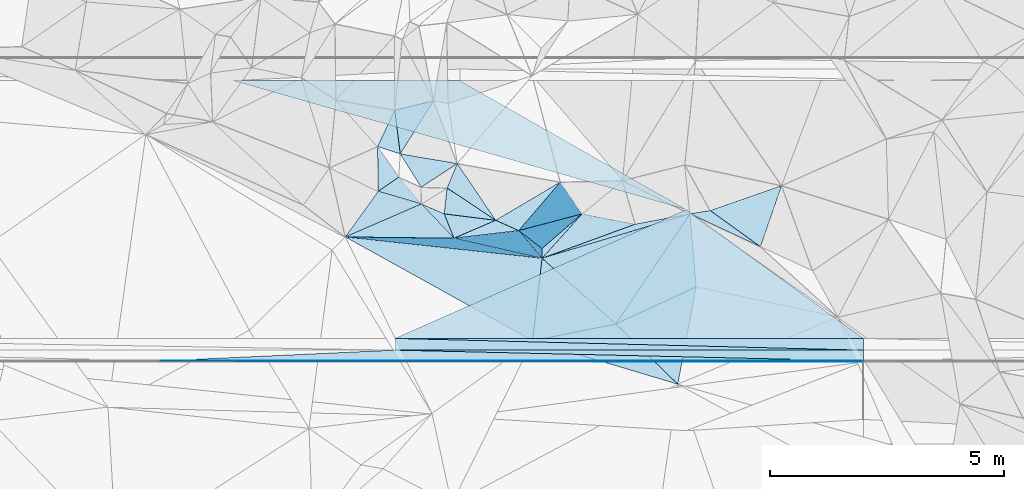
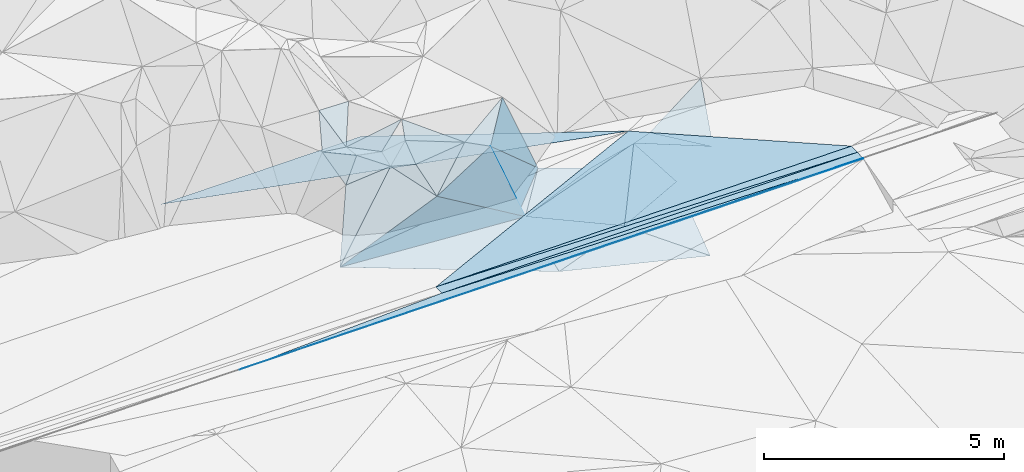
# One storey, part 48 of 275: 49 plates.
"""IFC2X3 building model written with IfcOpenShell, lengths in millimetres."""

from ifc_helpers import new_model, si_unit, frame, origin_with_axes, place, context, subcontext, project, spatial, polyline, outline, extrude, material, type_object, element, save


model = new_model("IFC2X3")

# Units and contexts
model_context = context("Model", 3, precision=1e-05, world=origin_with_axes())
body_context = subcontext(model_context, "Body", "Model", "MODEL_VIEW")
ifc_project = project(units=[si_unit("LENGTHUNIT", "METRE", prefix="MILLI"), si_unit("AREAUNIT", "SQUARE_METRE"), si_unit("VOLUMEUNIT", "CUBIC_METRE"), si_unit("MASSUNIT", "GRAM", prefix="KILO"), si_unit("TIMEUNIT", "SECOND"), si_unit("PLANEANGLEUNIT", "RADIAN"), si_unit("SOLIDANGLEUNIT", "STERADIAN"), si_unit("THERMODYNAMICTEMPERATUREUNIT", "DEGREE_CELSIUS"), si_unit("LUMINOUSINTENSITYUNIT", "LUMEN")], contexts=[model_context])

# Site, building, storey
site_placement = place(None, origin_with_axes())
site = spatial("IfcSite", under=ifc_project, at=site_placement, CompositionType="ELEMENT")
building_placement = place(site_placement, origin_with_axes())
building = spatial("IfcBuilding", under=site, at=building_placement, Name="Undefined", CompositionType="ELEMENT")
storey_placement = place(building_placement, origin_with_axes())
storey = spatial("IfcBuildingStorey", under=building, at=storey_placement, Name="Undefined", CompositionType="ELEMENT", Elevation=0.0)

# Plates
ifc_material = material()
plate_type_1 = type_object("IfcPlateType", PredefinedType="NOTDEFINED")
for number, where, z_axis, x_axis, name in (
    (1, (-124610.502362477, 63294.0443863483, 49008.9291654633), (0.008324340579686, 0.024990848492353, -0.999653021225638), (0.808589546700831, -0.588319091752625, -0.00797441192262458), "00_PR"),
    (2, (-124610.502362477, 63294.0443863483, 49008.9291654633), (0.008324340579686, 0.024990848492353, -0.999653021225638), (0.808589546700831, -0.588319091752625, -0.00797441192262458), "00_PR"),
    (3, (-124610.502362477, 63294.0443863483, 49008.9291654633), (0.008324340579686, 0.024990848492353, -0.999653021225638), (0.808589546700831, -0.588319091752625, -0.00797441192262458), "00_PR"),
):
    element("IfcPlate", number, at=place(storey_placement, frame(where, z_axis=z_axis, x_axis=x_axis)), inside=storey, type_object=plate_type_1, material=ifc_material, Name=name, context=body_context, shape_type="SweptSolid", body=[
        extrude(outline(polyline([(0.0, 0.0), (4674.70166015625, 3.60887497663498e-09), (-3410.86694335938, 5884.76953125), (0.0, 0.0)])), frame((-8.85201319254618e-08, 2.18876761149539e-07, -0.5000001331573), z_axis=(0.0, 0.0, 1.0), x_axis=(1.0, 0.0, 0.0)), (0.0, 0.0, 1.0), 1.0),
    ])
plate_type_2 = type_object("IfcPlateType", PredefinedType="NOTDEFINED")
plate_1_placement = place(storey_placement, frame((-120830.601639584, 60293.8280401885, 48965.3971659145), z_axis=(0.008324340579686, 0.024990848492353, -0.999653021225638), x_axis=(-0.999965344853481, 5.72919765649429e-05, -0.00832501109232228)))
element("IfcPlate", 4, at=plate_1_placement, inside=storey, type_object=plate_type_2, material=ifc_material, Name="00_PR", context=body_context, shape_type="SweptSolid", body=[
    extrude(outline(polyline([(0.0, 0.0), (10000.3466796875, 4.4623448047787e-08), (10000.294921875, 250.078109741211), (0.0, 0.0)])), frame((-8.85201319254618e-08, 2.18876761149539e-07, -0.5000001331573), z_axis=(0.0, 0.0, 1.0), x_axis=(1.0, 0.0, 0.0)), (0.0, 0.0, 1.0), 1.0),
])
plate_2_placement = place(storey_placement, frame((-120830.587315527, 60543.8280489618, 48971.6511662542), z_axis=(0.00832424080938101, 0.0250068329668296, -0.999652622324334), x_axis=(-5.72749691740062e-05, -0.999687245018328, -0.0250081760079334)))
element("IfcPlate", 5, at=plate_2_placement, inside=storey, type_object=plate_type_2, material=ifc_material, Name="00_PR", context=body_context, shape_type="SweptSolid", body=[
    extrude(outline(polyline([(0.0, 0.0), (250.078216552734, 4.07453626394272e-10), (2.08209180831909, 10000.3466796875), (0.0, 0.0)])), frame((-8.85201319254618e-08, 2.18876761149539e-07, -0.5000001331573), z_axis=(0.0, 0.0, 1.0), x_axis=(1.0, 0.0, 0.0)), (0.0, 0.0, 1.0), 1.0),
])
plate_3_placement = place(storey_placement, frame((-120830.601639584, 60293.8280401885, 48965.3971659145), z_axis=(0.008324340579686, 0.024990848492353, -0.999653021225638), x_axis=(-0.999965344853481, 5.72919765649429e-05, -0.00832501109232228)))
element("IfcPlate", 6, at=plate_3_placement, inside=storey, type_object=plate_type_2, material=ifc_material, Name="00_PR", context=body_context, shape_type="SweptSolid", body=[
    extrude(outline(polyline([(0.0, 0.0), (10000.3466796875, 4.4623448047787e-08), (10000.294921875, 250.078109741211), (0.0, 0.0)])), frame((-8.85201319254618e-08, 2.18876761149539e-07, -0.5000001331573), z_axis=(0.0, 0.0, 1.0), x_axis=(1.0, 0.0, 0.0)), (0.0, 0.0, 1.0), 1.0),
])
plate_4_placement = place(storey_placement, frame((-120830.587315527, 60543.8280489618, 48971.6511662542), z_axis=(0.00832424080938101, 0.0250068329668296, -0.999652622324334), x_axis=(-5.72749691740062e-05, -0.999687245018328, -0.0250081760079334)))
element("IfcPlate", 7, at=plate_4_placement, inside=storey, type_object=plate_type_2, material=ifc_material, Name="00_PR", context=body_context, shape_type="SweptSolid", body=[
    extrude(outline(polyline([(0.0, 0.0), (250.078216552734, 4.07453626394272e-10), (2.08209180831909, 10000.3466796875), (0.0, 0.0)])), frame((-8.85201319254618e-08, 2.18876761149539e-07, -0.5000001331573), z_axis=(0.0, 0.0, 1.0), x_axis=(1.0, 0.0, 0.0)), (0.0, 0.0, 1.0), 1.0),
])
plate_5_placement = place(storey_placement, frame((-120830.601639584, 60293.8280401885, 48965.3971659145), z_axis=(0.008324340579686, 0.024990848492353, -0.999653021225638), x_axis=(-0.999965344853481, 5.72919765649429e-05, -0.00832501109232228)))
element("IfcPlate", 8, at=plate_5_placement, inside=storey, type_object=plate_type_2, material=ifc_material, Name="00_PR", context=body_context, shape_type="SweptSolid", body=[
    extrude(outline(polyline([(0.0, 0.0), (10000.3466796875, 4.4623448047787e-08), (10000.294921875, 250.078109741211), (0.0, 0.0)])), frame((-8.85201319254618e-08, 2.18876761149539e-07, -0.5000001331573), z_axis=(0.0, 0.0, 1.0), x_axis=(1.0, 0.0, 0.0)), (0.0, 0.0, 1.0), 1.0),
])
plate_6_placement = place(storey_placement, frame((-120830.587315527, 60543.8280489618, 48971.6511662542), z_axis=(0.00832424080938101, 0.0250068329668296, -0.999652622324334), x_axis=(-5.72749691740062e-05, -0.999687245018328, -0.0250081760079334)))
element("IfcPlate", 9, at=plate_6_placement, inside=storey, type_object=plate_type_2, material=ifc_material, Name="00_PR", context=body_context, shape_type="SweptSolid", body=[
    extrude(outline(polyline([(0.0, 0.0), (250.078216552734, 4.07453626394272e-10), (2.08209180831909, 10000.3466796875), (0.0, 0.0)])), frame((-8.85201319254618e-08, 2.18876761149539e-07, -0.5000001331573), z_axis=(0.0, 0.0, 1.0), x_axis=(1.0, 0.0, 0.0)), (0.0, 0.0, 1.0), 1.0),
])
plate_type_3 = type_object("IfcPlateType", PredefinedType="NOTDEFINED")
for number, where, z_axis, x_axis, name in (
    (10, (-135830.614983984, 60064.7000444183, 48829.0156227603), (0.00831779862514196, 0.049539601639022, -0.998737524125072), (0.999965340787191, -5.73519775278889e-05, 0.0083254990906575), "00_PR"),
    (11, (-135830.614983984, 60064.7000444183, 48829.0156227603), (0.00831779862514196, 0.049539601639022, -0.998737524125072), (0.999965340787191, -5.73519775278889e-05, 0.0083254990906575), "00_PR"),
    (12, (-135830.614983984, 60064.7000444183, 48829.0156227603), (0.00831779862514196, 0.049539601639022, -0.998737524125072), (0.999965340787191, -5.73519775278889e-05, 0.0083254990906575), "00_PR"),
):
    element("IfcPlate", number, at=place(storey_placement, frame(where, z_axis=z_axis, x_axis=x_axis)), inside=storey, type_object=plate_type_3, material=ifc_material, Name=name, context=body_context, shape_type="SweptSolid", body=[
        extrude(outline(polyline([(0.0, 0.0), (15000.51953125, -1.61511707119644e-07), (15000.51171875, 20.0235919952393), (0.0, 0.0)])), frame((-8.85201319254618e-08, 2.18876761149539e-07, -0.5000001331573), z_axis=(0.0, 0.0, 1.0), x_axis=(1.0, 0.0, 0.0)), (0.0, 0.0, 1.0), 1.0),
    ])
plate_type_4 = type_object("IfcPlateType", PredefinedType="NOTDEFINED")
plate_7_placement = place(storey_placement, frame((-130830.60171673, 60294.413452539, 48882.1446321262), z_axis=(0.00831765539205462, 0.0499426003588408, -0.998717454177194), x_axis=(0.999708562495105, -0.0230507050000655, 0.00717321914976939)))
element("IfcPlate", 13, at=plate_7_placement, inside=storey, type_object=plate_type_4, material=ifc_material, Name="00_PR", context=body_context, shape_type="SweptSolid", body=[
    extrude(outline(polyline([(0.0, 0.0), (10002.9013671875, 4.3117324821651e-08), (-4993.64208984375, 345.343017578125), (0.0, 0.0)])), frame((-8.85201319254618e-08, 2.18876761149539e-07, -0.5000001331573), z_axis=(0.0, 0.0, 1.0), x_axis=(1.0, 0.0, 0.0)), (0.0, 0.0, 1.0), 1.0),
])
plate_8_placement = place(storey_placement, frame((-120830.601646001, 60293.8405085212, 48965.3976334797), z_axis=(0.00831748675117263, 0.049935177931012, -0.998717826725418), x_axis=(-5.96829523358933e-05, -0.998752347891058, -0.0499374010141037)))
element("IfcPlate", 14, at=plate_8_placement, inside=storey, type_object=plate_type_4, material=ifc_material, Name="00_PR", context=body_context, shape_type="SweptSolid", body=[
    extrude(outline(polyline([(0.0, 0.0), (230.288314819336, -3.49245965480804e-10), (4.18204641342163, 10000.345703125), (0.0, 0.0)])), frame((-8.85201319254618e-08, 2.18876761149539e-07, -0.5000001331573), z_axis=(0.0, 0.0, 1.0), x_axis=(1.0, 0.0, 0.0)), (0.0, 0.0, 1.0), 1.0),
])
plate_9_placement = place(storey_placement, frame((-130830.60171673, 60294.413452539, 48882.1446321262), z_axis=(0.00831765539205462, 0.0499426003588408, -0.998717454177194), x_axis=(0.999708562495105, -0.0230507050000655, 0.00717321914976939)))
element("IfcPlate", 15, at=plate_9_placement, inside=storey, type_object=plate_type_4, material=ifc_material, Name="00_PR", context=body_context, shape_type="SweptSolid", body=[
    extrude(outline(polyline([(0.0, 0.0), (10002.9013671875, 4.3117324821651e-08), (-4993.64208984375, 345.343017578125), (0.0, 0.0)])), frame((-8.85201319254618e-08, 2.18876761149539e-07, -0.5000001331573), z_axis=(0.0, 0.0, 1.0), x_axis=(1.0, 0.0, 0.0)), (0.0, 0.0, 1.0), 1.0),
])
plate_10_placement = place(storey_placement, frame((-120830.601646001, 60293.8405085212, 48965.3976334797), z_axis=(0.00831748675117263, 0.049935177931012, -0.998717826725418), x_axis=(-5.96829523358933e-05, -0.998752347891058, -0.0499374010141037)))
element("IfcPlate", 16, at=plate_10_placement, inside=storey, type_object=plate_type_4, material=ifc_material, Name="00_PR", context=body_context, shape_type="SweptSolid", body=[
    extrude(outline(polyline([(0.0, 0.0), (230.288314819336, -3.49245965480804e-10), (4.18204641342163, 10000.345703125), (0.0, 0.0)])), frame((-8.85201319254618e-08, 2.18876761149539e-07, -0.5000001331573), z_axis=(0.0, 0.0, 1.0), x_axis=(1.0, 0.0, 0.0)), (0.0, 0.0, 1.0), 1.0),
])
plate_11_placement = place(storey_placement, frame((-130830.60171673, 60294.413452539, 48882.1446321262), z_axis=(0.00831765539205462, 0.0499426003588408, -0.998717454177194), x_axis=(0.999708562495105, -0.0230507050000655, 0.00717321914976939)))
element("IfcPlate", 17, at=plate_11_placement, inside=storey, type_object=plate_type_4, material=ifc_material, Name="00_PR", context=body_context, shape_type="SweptSolid", body=[
    extrude(outline(polyline([(0.0, 0.0), (10002.9013671875, 4.3117324821651e-08), (-4993.64208984375, 345.343017578125), (0.0, 0.0)])), frame((-8.85201319254618e-08, 2.18876761149539e-07, -0.5000001331573), z_axis=(0.0, 0.0, 1.0), x_axis=(1.0, 0.0, 0.0)), (0.0, 0.0, 1.0), 1.0),
])
plate_12_placement = place(storey_placement, frame((-120830.601646001, 60293.8405085212, 48965.3976334797), z_axis=(0.00831748675117263, 0.049935177931012, -0.998717826725418), x_axis=(-5.96829523358933e-05, -0.998752347891058, -0.0499374010141037)))
element("IfcPlate", 18, at=plate_12_placement, inside=storey, type_object=plate_type_4, material=ifc_material, Name="00_PR", context=body_context, shape_type="SweptSolid", body=[
    extrude(outline(polyline([(0.0, 0.0), (230.288314819336, -3.49245965480804e-10), (4.18204641342163, 10000.345703125), (0.0, 0.0)])), frame((-8.85201319254618e-08, 2.18876761149539e-07, -0.5000001331573), z_axis=(0.0, 0.0, 1.0), x_axis=(1.0, 0.0, 0.0)), (0.0, 0.0, 1.0), 1.0),
])
plate_type_5 = type_object("IfcPlateType", PredefinedType="NOTDEFINED")
plate_13_placement = place(storey_placement, frame((-126114.695033542, 60852.7403297663, 48599.5005975447), z_axis=(0.00639754250018912, 0.0492102304275293, -0.99876795336616), x_axis=(0.557695812458765, 0.828856477377227, 0.044410817103184)))
element("IfcPlate", 19, at=plate_13_placement, inside=storey, type_object=plate_type_5, material=ifc_material, Name="00", context=body_context, shape_type="SweptSolid", body=[
    extrude(outline(polyline([(0.0, 0.0), (2837.14672851563, -1.85973476618528e-08), (1615.65490722656, 982.425109863281), (0.0, 0.0)])), frame((-8.85201319254618e-08, 2.18876761149539e-07, -0.5000001331573), z_axis=(0.0, 0.0, 1.0), x_axis=(1.0, 0.0, 0.0)), (0.0, 0.0, 1.0), 1.0),
])
plate_type_6 = type_object("IfcPlateType", PredefinedType="NOTDEFINED")
plate_14_placement = place(storey_placement, frame((-127689.030648532, 62255.3389630177, 48539.887444943), z_axis=(0.109830524960829, 0.968132294410708, -0.22507135825308), x_axis=(-0.993946047957137, 0.107641771830923, -0.0220114222050292)))
element("IfcPlate", 20, at=plate_14_placement, inside=storey, type_object=plate_type_6, material=ifc_material, Name="00", context=body_context, shape_type="SweptSolid", body=[
    extrude(outline(polyline([(0.0, 0.0), (4225.0791015625, -6.38101482763886e-09), (1894.64685058594, 987.28076171875), (0.0, 0.0)])), frame((-8.85201319254618e-08, 2.18876761149539e-07, -0.5000001331573), z_axis=(0.0, 0.0, 1.0), x_axis=(1.0, 0.0, 0.0)), (0.0, 0.0, 1.0), 1.0),
])
plate_type_7 = type_object("IfcPlateType", PredefinedType="NOTDEFINED")
plate_15_placement = place(storey_placement, frame((-130715.361903909, 64482.6576847983, 50019.5544333063), z_axis=(-0.280613128558549, 0.356665372953221, -0.891092634812298), x_axis=(-0.114092131194023, 0.909417436755586, 0.399928632789034)))
element("IfcPlate", 21, at=plate_15_placement, inside=storey, type_object=plate_type_7, material=ifc_material, Name="00", context=body_context, shape_type="SweptSolid", body=[
    extrude(outline(polyline([(0.0, 0.0), (1025.18286132813, -4.36557456851006e-10), (1042.74072265625, 871.889770507813), (0.0, 0.0)])), frame((-8.85201319254618e-08, 2.18876761149539e-07, -0.5000001331573), z_axis=(0.0, 0.0, 1.0), x_axis=(1.0, 0.0, 0.0)), (0.0, 0.0, 1.0), 1.0),
])
plate_type_8 = type_object("IfcPlateType", PredefinedType="NOTDEFINED")
for number, where, z_axis, x_axis, name in (
    (22, (-134278.700031969, 66044.5731858637, 48859.6831648337), (0.00832149793297365, -0.0249918019511436, -0.9996530210565), (0.999965340787191, -5.73519775278889e-05, 0.0083254990906575), "00_PR"),
    (23, (-134278.700031969, 66044.5731858637, 48859.6831648337), (0.00832149793297365, -0.0249918019511436, -0.9996530210565), (0.999965340787191, -5.73519775278889e-05, 0.0083254990906575), "00_PR"),
):
    element("IfcPlate", number, at=place(storey_placement, frame(where, z_axis=z_axis, x_axis=x_axis)), inside=storey, type_object=plate_type_8, material=ifc_material, Name=name, context=body_context, shape_type="SweptSolid", body=[
        extrude(outline(polyline([(0.0, 0.0), (4834.345703125, 2.56695784628391e-08), (9669.2626953125, 2750.85961914063), (0.0, 0.0)])), frame((-8.85201319254618e-08, 2.18876761149539e-07, -0.5000001331573), z_axis=(0.0, 0.0, 1.0), x_axis=(1.0, 0.0, 0.0)), (0.0, 0.0, 1.0), 1.0),
    ])
plate_type_9 = type_object("IfcPlateType", PredefinedType="NOTDEFINED")
plate_16_placement = place(storey_placement, frame((-127689.058861388, 62254.8636245621, 48539.5007750869), z_axis=(0.0535833637526715, 0.0174421420112039, -0.99841103500062), x_axis=(0.956100411695855, 0.287572953610407, 0.0563364811361456)))
element("IfcPlate", 24, at=plate_16_placement, inside=storey, type_object=plate_type_9, material=ifc_material, Name="00", context=body_context, shape_type="SweptSolid", body=[
    extrude(outline(polyline([(0.0, 0.0), (3301.59057617188, 1.31840351969004e-08), (1105.43530273438, 1796.19116210938), (0.0, 0.0)])), frame((-8.85201319254618e-08, 2.18876761149539e-07, -0.5000001331573), z_axis=(0.0, 0.0, 1.0), x_axis=(1.0, 0.0, 0.0)), (0.0, 0.0, 1.0), 1.0),
])
plate_type_10 = type_object("IfcPlateType", PredefinedType="NOTDEFINED")
plate_17_placement = place(storey_placement, frame((-130832.074062171, 65415.0064448036, 50429.5594633423), z_axis=(0.225671530064782, 0.415757775591195, -0.881032253980342), x_axis=(0.114092131197188, -0.909417436756775, -0.399928632785427)))
element("IfcPlate", 25, at=plate_17_placement, inside=storey, type_object=plate_type_10, material=ifc_material, Name="00", context=body_context, shape_type="SweptSolid", body=[
    extrude(outline(polyline([(0.0, 0.0), (1025.18286132813, -4.36557456851006e-10), (846.775695800781, 480.282073974609), (0.0, 0.0)])), frame((-8.85201319254618e-08, 2.18876761149539e-07, -0.5000001331573), z_axis=(0.0, 0.0, 1.0), x_axis=(1.0, 0.0, 0.0)), (0.0, 0.0, 1.0), 1.0),
])
plate_type_11 = type_object("IfcPlateType", PredefinedType="NOTDEFINED")
plate_18_placement = place(storey_placement, frame((-126836.031941781, 63201.7760402347, 48909.5268644143), z_axis=(0.0570170019140308, 0.318421411265497, -0.946232987345307), x_axis=(-0.642825708681639, -0.713464234971346, -0.278825920019466)))
element("IfcPlate", 26, at=plate_18_placement, inside=storey, type_object=plate_type_11, material=ifc_material, Name="00", context=body_context, shape_type="SweptSolid", body=[
    extrude(outline(polyline([(0.0, 0.0), (1326.99279785156, -4.62750904262066e-09), (1159.74255371094, 142.468673706055), (0.0, 0.0)])), frame((-8.85201319254618e-08, 2.18876761149539e-07, -0.5000001331573), z_axis=(0.0, 0.0, 1.0), x_axis=(1.0, 0.0, 0.0)), (0.0, 0.0, 1.0), 1.0),
])
plate_type_12 = type_object("IfcPlateType", PredefinedType="NOTDEFINED")
plate_19_placement = place(storey_placement, frame((-131888.567773085, 62709.7207887219, 48446.5053806199), z_axis=(0.0372586533999102, 0.14176098876546, -0.989199481808935), x_axis=(0.993946048013709, -0.107641771323689, 0.0220114221309785)))
element("IfcPlate", 27, at=plate_19_placement, inside=storey, type_object=plate_type_12, material=ifc_material, Name="00", context=body_context, shape_type="SweptSolid", body=[
    extrude(outline(polyline([(0.0, 0.0), (4225.0791015625, -6.38101482763886e-09), (4207.990234375, 1791.57971191406), (0.0, 0.0)])), frame((-8.85201319254618e-08, 2.18876761149539e-07, -0.5000001331573), z_axis=(0.0, 0.0, 1.0), x_axis=(1.0, 0.0, 0.0)), (0.0, 0.0, 1.0), 1.0),
])
plate_type_13 = type_object("IfcPlateType", PredefinedType="NOTDEFINED")
plate_20_placement = place(storey_placement, frame((-124532.384540762, 63204.2374024508, 48725.5067217882), z_axis=(0.0976341492947302, -0.131344559542837, -0.986517196793848), x_axis=(-0.956100411837469, -0.287572953132265, -0.0563364811734915)))
element("IfcPlate", 28, at=plate_20_placement, inside=storey, type_object=plate_type_13, material=ifc_material, Name="00", context=body_context, shape_type="SweptSolid", body=[
    extrude(outline(polyline([(0.0, 0.0), (3301.59057617188, 1.31840351969004e-08), (1185.35766601563, 125.092262268066), (0.0, 0.0)])), frame((-8.85201319254618e-08, 2.18876761149539e-07, -0.5000001331573), z_axis=(0.0, 0.0, 1.0), x_axis=(1.0, 0.0, 0.0)), (0.0, 0.0, 1.0), 1.0),
])
plate_type_14 = type_object("IfcPlateType", PredefinedType="NOTDEFINED")
plate_21_placement = place(storey_placement, frame((-128187.643238189, 62844.888515966, 50149.8356394683), z_axis=(-0.938630578521017, 0.104549262363026, -0.328697564342434), x_axis=(0.298799227129321, -0.229604498938398, -0.926283323791467)))
element("IfcPlate", 29, at=plate_21_placement, inside=storey, type_object=plate_type_14, material=ifc_material, Name="00", context=body_context, shape_type="SweptSolid", body=[
    extrude(outline(polyline([(0.0, 0.0), (1662.55822753906, 7.8580342233181e-10), (1775.60693359375, 188.387893676758), (0.0, 0.0)])), frame((-8.85201319254618e-08, 2.18876761149539e-07, -0.5000001331573), z_axis=(0.0, 0.0, 1.0), x_axis=(1.0, 0.0, 0.0)), (0.0, 0.0, 1.0), 1.0),
])
plate_type_15 = type_object("IfcPlateType", PredefinedType="NOTDEFINED")
plate_22_placement = place(storey_placement, frame((-129569.26330124, 62682.4277328463, 49459.697025726), z_axis=(0.238035656413421, 0.759075026671159, -0.605924195060745), x_axis=(-0.260399215168144, 0.650893203827743, 0.713113094782778)))
element("IfcPlate", 30, at=plate_22_placement, inside=storey, type_object=plate_type_15, material=ifc_material, Name="00", context=body_context, shape_type="SweptSolid", body=[
    extrude(outline(polyline([(0.0, 0.0), (799.312194824219, 6.40284270048141e-10), (609.148742675781, 1121.9794921875), (0.0, 0.0)])), frame((-8.85201319254618e-08, 2.18876761149539e-07, -0.5000001331573), z_axis=(0.0, 0.0, 1.0), x_axis=(1.0, 0.0, 0.0)), (0.0, 0.0, 1.0), 1.0),
])
plate_type_16 = type_object("IfcPlateType", PredefinedType="NOTDEFINED")
plate_23_placement = place(storey_placement, frame((-130269.705070246, 63771.8692066269, 50179.5258217105), z_axis=(0.316973033588439, -0.0148668077271932, -0.948318023663868), x_axis=(-0.521645331900928, 0.832324895572777, -0.187407086087309)))
element("IfcPlate", 31, at=plate_23_placement, inside=storey, type_object=plate_type_16, material=ifc_material, Name="00", context=body_context, shape_type="SweptSolid", body=[
    extrude(outline(polyline([(0.0, 0.0), (853.756408691406, 2.48837750405073e-09), (-28.9309692382813, 955.124572753906), (0.0, 0.0)])), frame((-8.85201319254618e-08, 2.18876761149539e-07, -0.5000001331573), z_axis=(0.0, 0.0, 1.0), x_axis=(1.0, 0.0, 0.0)), (0.0, 0.0, 1.0), 1.0),
])
plate_type_17 = type_object("IfcPlateType", PredefinedType="NOTDEFINED")
plate_24_placement = place(storey_placement, frame((-128678.094167146, 63065.2224209586, 50289.5174869836), z_axis=(0.151542064683491, 0.214020773055344, -0.965002648355049), x_axis=(-0.832814743254965, 0.553493585918912, -0.00802831014544399)))
element("IfcPlate", 32, at=plate_24_placement, inside=storey, type_object=plate_type_17, material=ifc_material, Name="00", context=body_context, shape_type="SweptSolid", body=[
    extrude(outline(polyline([(0.0, 0.0), (1245.59228515625, 8.29459168016911e-10), (1352.60961914063, 575.540832519531), (0.0, 0.0)])), frame((-8.85201319254618e-08, 2.18876761149539e-07, -0.5000001331573), z_axis=(0.0, 0.0, 1.0), x_axis=(1.0, 0.0, 0.0)), (0.0, 0.0, 1.0), 1.0),
])
plate_type_18 = type_object("IfcPlateType", PredefinedType="NOTDEFINED")
plate_25_placement = place(storey_placement, frame((-124532.383010793, 63204.5283061892, 48725.5564312499), z_axis=(0.100695931091906, 0.450459089485422, -0.887100297689894), x_axis=(0.969575789879341, 0.15552861216525, 0.189033432169562)))
element("IfcPlate", 33, at=plate_25_placement, inside=storey, type_object=plate_type_18, material=ifc_material, Name="00", context=body_context, shape_type="SweptSolid", body=[
    extrude(outline(polyline([(0.0, 0.0), (444.365844726563, 2.3283064365387e-09), (1314.36975097656, 1031.74279785156), (0.0, 0.0)])), frame((-8.85201319254618e-08, 2.18876761149539e-07, -0.5000001331573), z_axis=(0.0, 0.0, 1.0), x_axis=(1.0, 0.0, 0.0)), (0.0, 0.0, 1.0), 1.0),
])
plate_type_19 = type_object("IfcPlateType", PredefinedType="NOTDEFINED")
plate_26_placement = place(storey_placement, frame((-123027.784599884, 62501.9133330681, 48539.5663739485), z_axis=(0.127800931242527, 0.48122022455354, -0.867233542625159), x_axis=(-0.795601984343141, 0.571833302009626, 0.200060383939508)))
element("IfcPlate", 34, at=plate_26_placement, inside=storey, type_object=plate_type_19, material=ifc_material, Name="00", context=body_context, shape_type="SweptSolid", body=[
    extrude(outline(polyline([(0.0, 0.0), (1349.59252929688, 4.3000909499824e-09), (544.534729003906, 1493.74755859375), (0.0, 0.0)])), frame((-8.85201319254618e-08, 2.18876761149539e-07, -0.5000001331573), z_axis=(0.0, 0.0, 1.0), x_axis=(1.0, 0.0, 0.0)), (0.0, 0.0, 1.0), 1.0),
])
plate_type_20 = type_object("IfcPlateType", PredefinedType="NOTDEFINED")
plate_27_placement = place(storey_placement, frame((-128678.073400098, 63065.513136037, 50289.7127693048), z_axis=(0.193076804516631, 0.795450953373492, -0.574438097913822), x_axis=(0.882994961566135, -0.396144552025615, -0.251772499986087)))
element("IfcPlate", 35, at=plate_27_placement, inside=storey, type_object=plate_type_20, material=ifc_material, Name="00", context=body_context, shape_type="SweptSolid", body=[
    extrude(outline(polyline([(0.0, 0.0), (556.057556152344, -3.11047188006341e-09), (-426.214874267578, 1203.42883300781), (0.0, 0.0)])), frame((-8.85201319254618e-08, 2.18876761149539e-07, -0.5000001331573), z_axis=(0.0, 0.0, 1.0), x_axis=(1.0, 0.0, 0.0)), (0.0, 0.0, 1.0), 1.0),
])
plate_type_21 = type_object("IfcPlateType", PredefinedType="NOTDEFINED")
plate_28_placement = place(storey_placement, frame((-126836.327334838, 63201.9990263813, 48909.8191523468), z_axis=(-0.533764266234758, 0.764395105476838, -0.361657062441652), x_axis=(-0.731169198738589, -0.632037993052399, -0.2567480830586)))
element("IfcPlate", 36, at=plate_28_placement, inside=storey, type_object=plate_type_21, material=ifc_material, Name="00", context=body_context, shape_type="SweptSolid", body=[
    extrude(outline(polyline([(0.0, 0.0), (1168.46057128906, -3.40514816343784e-09), (895.023803710938, 1639.91845703125), (0.0, 0.0)])), frame((-8.85201319254618e-08, 2.18876761149539e-07, -0.5000001331573), z_axis=(0.0, 0.0, 1.0), x_axis=(1.0, 0.0, 0.0)), (0.0, 0.0, 1.0), 1.0),
])
plate_type_22 = type_object("IfcPlateType", PredefinedType="NOTDEFINED")
plate_29_placement = place(storey_placement, frame((-130264.269111503, 63413.6891535112, 50019.6133765996), z_axis=(0.412116277449734, 0.481960274246999, -0.773223426901133), x_axis=(-0.909441941770582, 0.269246470721673, -0.316893819050604)))
element("IfcPlate", 37, at=plate_29_placement, inside=storey, type_object=plate_type_22, material=ifc_material, Name="00", context=body_context, shape_type="SweptSolid", body=[
    extrude(outline(polyline([(0.0, 0.0), (1009.80194091797, 3.94356902688742e-09), (562.189453125, 506.402038574219), (0.0, 0.0)])), frame((-8.85201319254618e-08, 2.18876761149539e-07, -0.5000001331573), z_axis=(0.0, 0.0, 1.0), x_axis=(1.0, 0.0, 0.0)), (0.0, 0.0, 1.0), 1.0),
])
plate_type_23 = type_object("IfcPlateType", PredefinedType="NOTDEFINED")
plate_30_placement = place(storey_placement, frame((-128187.473525632, 62845.161923702, 50149.7672457985), z_axis=(-0.599206277182353, 0.651364298956338, -0.465485109783744), x_axis=(0.633614693796485, 0.741234885120069, 0.221592565051775)))
element("IfcPlate", 38, at=plate_30_placement, inside=storey, type_object=plate_type_23, material=ifc_material, Name="00", context=body_context, shape_type="SweptSolid", body=[
    extrude(outline(polyline([(0.0, 0.0), (1398.9638671875, -5.3114490583539e-09), (845.768798828125, 1665.85571289063), (0.0, 0.0)])), frame((-8.85201319254618e-08, 2.18876761149539e-07, -0.5000001331573), z_axis=(0.0, 0.0, 1.0), x_axis=(1.0, 0.0, 0.0)), (0.0, 0.0, 1.0), 1.0),
])
plate_type_24 = type_object("IfcPlateType", PredefinedType="NOTDEFINED")
plate_31_placement = place(storey_placement, frame((-131888.378392461, 62709.9444276296, 48446.6535390006), z_axis=(0.415830907402332, 0.589048676513838, -0.69289704368416), x_axis=(0.406112399880446, 0.561437595220691, 0.721013554197251)))
element("IfcPlate", 39, at=plate_31_placement, inside=storey, type_object=plate_type_24, material=ifc_material, Name="00", context=body_context, shape_type="SweptSolid", body=[
    extrude(outline(polyline([(0.0, 0.0), (1737.83142089844, -1.40571501106024e-08), (2188.86474609375, 903.476013183594), (0.0, 0.0)])), frame((-8.85201319254618e-08, 2.18876761149539e-07, -0.5000001331573), z_axis=(0.0, 0.0, 1.0), x_axis=(1.0, 0.0, 0.0)), (0.0, 0.0, 1.0), 1.0),
])
plate_type_25 = type_object("IfcPlateType", PredefinedType="NOTDEFINED")
plate_32_placement = place(storey_placement, frame((-129569.213223342, 62682.4248395372, 49459.7179527583), z_axis=(0.338196020032963, 0.753291262472355, -0.564070674576041), x_axis=(-0.602337111263572, 0.633799282968161, 0.485271545944845)))
element("IfcPlate", 40, at=plate_32_placement, inside=storey, type_object=plate_type_25, material=ifc_material, Name="00", context=body_context, shape_type="SweptSolid", body=[
    extrude(outline(polyline([(0.0, 0.0), (1153.99304199219, -5.54427970200777e-09), (731.720153808594, 321.691772460938), (0.0, 0.0)])), frame((-8.85201319254618e-08, 2.18876761149539e-07, -0.5000001331573), z_axis=(0.0, 0.0, 1.0), x_axis=(1.0, 0.0, 0.0)), (0.0, 0.0, 1.0), 1.0),
])
plate_type_26 = type_object("IfcPlateType", PredefinedType="NOTDEFINED")
plate_33_placement = place(storey_placement, frame((-130264.336112759, 63413.8164043758, 50019.6916559466), z_axis=(0.278116262540021, 0.736462312147791, -0.616664096000975), x_axis=(0.602337111263058, -0.633799282966058, -0.48527154594823)))
element("IfcPlate", 41, at=plate_33_placement, inside=storey, type_object=plate_type_26, material=ifc_material, Name="00", context=body_context, shape_type="SweptSolid", body=[
    extrude(outline(polyline([(0.0, 0.0), (1153.99304199219, -5.54427970200777e-09), (231.136566162109, 2356.68701171875), (0.0, 0.0)])), frame((-8.85201319254618e-08, 2.18876761149539e-07, -0.5000001331573), z_axis=(0.0, 0.0, 1.0), x_axis=(1.0, 0.0, 0.0)), (0.0, 0.0, 1.0), 1.0),
])
plate_type_27 = type_object("IfcPlateType", PredefinedType="NOTDEFINED")
plate_34_placement = place(storey_placement, frame((-129777.393886728, 63202.5022687082, 50029.5545735783), z_axis=(0.257407162723916, 0.374386687369175, -0.890828917861987), x_axis=(0.101757115713408, 0.906265960621691, 0.41027734280622)))
element("IfcPlate", 42, at=plate_34_placement, inside=storey, type_object=plate_type_27, material=ifc_material, Name="00", context=body_context, shape_type="SweptSolid", body=[
    extrude(outline(polyline([(0.0, 0.0), (609.343933105469, 1.30967237055302e-10), (94.1996765136719, 1134.0751953125), (0.0, 0.0)])), frame((-8.85201319254618e-08, 2.18876761149539e-07, -0.5000001331573), z_axis=(0.0, 0.0, 1.0), x_axis=(1.0, 0.0, 0.0)), (0.0, 0.0, 1.0), 1.0),
])
plate_type_28 = type_object("IfcPlateType", PredefinedType="NOTDEFINED")
plate_35_placement = place(storey_placement, frame((-127689.146504784, 62255.0822095182, 48539.5588283847), z_axis=(-0.121881280655865, 0.45462392688883, -0.882304957781529), x_axis=(0.642825708680908, 0.713464234974218, 0.278825920013799)))
element("IfcPlate", 43, at=plate_35_placement, inside=storey, type_object=plate_type_28, material=ifc_material, Name="00", context=body_context, shape_type="SweptSolid", body=[
    extrude(outline(polyline([(0.0, 0.0), (1326.99279785156, -4.62750904262066e-09), (1825.17944335938, 1078.33679199219), (0.0, 0.0)])), frame((-8.85201319254618e-08, 2.18876761149539e-07, -0.5000001331573), z_axis=(0.0, 0.0, 1.0), x_axis=(1.0, 0.0, 0.0)), (0.0, 0.0, 1.0), 1.0),
])
plate_type_29 = type_object("IfcPlateType", PredefinedType="NOTDEFINED")
plate_36_placement = place(storey_placement, frame((-127689.058961156, 62255.3263062907, 48539.8354656199), z_axis=(0.0532133939879496, 0.942818514054603, -0.329031281576925), x_axis=(-0.880104157047854, 0.199954925863662, 0.430621295769199)))
element("IfcPlate", 44, at=plate_36_placement, inside=storey, type_object=plate_type_29, material=ifc_material, Name="00", context=body_context, shape_type="SweptSolid", body=[
    extrude(outline(polyline([(0.0, 0.0), (2136.44799804688, 6.64294930174947e-09), (1249.6396484375, 1275.41003417969), (0.0, 0.0)])), frame((-8.85201319254618e-08, 2.18876761149539e-07, -0.5000001331573), z_axis=(0.0, 0.0, 1.0), x_axis=(1.0, 0.0, 0.0)), (0.0, 0.0, 1.0), 1.0),
])
plate_type_30 = type_object("IfcPlateType", PredefinedType="NOTDEFINED")
plate_37_placement = place(storey_placement, frame((-127300.82038469, 63881.9787381641, 50459.5368947094), z_axis=(-0.101095275999648, 0.363296911453232, -0.926172283810684), x_axis=(-0.633614693815063, -0.741234885097946, -0.221592565072655)))
element("IfcPlate", 45, at=plate_37_placement, inside=storey, type_object=plate_type_30, material=ifc_material, Name="00", context=body_context, shape_type="SweptSolid", body=[
    extrude(outline(polyline([(0.0, 0.0), (1398.9638671875, -5.3114490583539e-09), (1515.7646484375, 543.652099609375), (0.0, 0.0)])), frame((-8.85201319254618e-08, 2.18876761149539e-07, -0.5000001331573), z_axis=(0.0, 0.0, 1.0), x_axis=(1.0, 0.0, 0.0)), (0.0, 0.0, 1.0), 1.0),
])
plate_type_31 = type_object("IfcPlateType", PredefinedType="NOTDEFINED")
plate_38_placement = place(storey_placement, frame((-130747.375773429, 63987.168167705, 50119.6124606529), z_axis=(0.588575571007407, 0.22998538842531, -0.775039043096646), x_axis=(-0.643853826686804, -0.446416427080595, -0.621421454001514)))
element("IfcPlate", 46, at=plate_38_placement, inside=storey, type_object=plate_type_31, material=ifc_material, Name="00", context=body_context, shape_type="SweptSolid", body=[
    extrude(outline(polyline([(0.0, 0.0), (675.869812011719, -2.61934474110603e-10), (93.2132186889648, 802.939147949219), (0.0, 0.0)])), frame((-8.85201319254618e-08, 2.18876761149539e-07, -0.5000001331573), z_axis=(0.0, 0.0, 1.0), x_axis=(1.0, 0.0, 0.0)), (0.0, 0.0, 1.0), 1.0),
])
plate_type_32 = type_object("IfcPlateType", PredefinedType="NOTDEFINED")
plate_39_placement = place(storey_placement, frame((-124398.263195283, 61644.4853207381, 48649.5169290752), z_axis=(-0.0843777904530199, 0.243969430998865, -0.966105224712276), x_axis=(-0.18157647128362, -0.957093743803131, -0.225835228981432)))
element("IfcPlate", 47, at=plate_39_placement, inside=storey, type_object=plate_type_32, material=ifc_material, Name="00", context=body_context, shape_type="SweptSolid", body=[
    extrude(outline(polyline([(0.0, 0.0), (2169.72338867188, 3.78349795937538e-09), (1080.64465332031, 1551.67883300781), (0.0, 0.0)])), frame((-8.85201319254618e-08, 2.18876761149539e-07, -0.5000001331573), z_axis=(0.0, 0.0, 1.0), x_axis=(1.0, 0.0, 0.0)), (0.0, 0.0, 1.0), 1.0),
])
plate_type_33 = type_object("IfcPlateType", PredefinedType="NOTDEFINED")
plate_40_placement = place(storey_placement, frame((-127891.171506641, 60493.7880584184, 48279.5098233723), z_axis=(0.150832174566164, 0.127412050903516, -0.980314145771753), x_axis=(0.112834535244143, 0.982959564546054, 0.145116718966737)))
element("IfcPlate", 48, at=plate_40_placement, inside=storey, type_object=plate_type_33, material=ifc_material, Name="00", context=body_context, shape_type="SweptSolid", body=[
    extrude(outline(polyline([(0.0, 0.0), (1791.66125488281, -6.69388100504875e-10), (599.767395019531, 1740.02270507813), (0.0, 0.0)])), frame((-8.85201319254618e-08, 2.18876761149539e-07, -0.5000001331573), z_axis=(0.0, 0.0, 1.0), x_axis=(1.0, 0.0, 0.0)), (0.0, 0.0, 1.0), 1.0),
])
plate_type_34 = type_object("IfcPlateType", PredefinedType="NOTDEFINED")
plate_41_placement = place(storey_placement, frame((-126114.656304755, 60852.9152106271, 48599.5434209489), z_axis=(0.0838543405173534, 0.398971732810526, -0.913121024834368), x_axis=(0.697623111477999, -0.67782847353498, -0.232100311927827)))
element("IfcPlate", 49, at=plate_41_placement, inside=storey, type_object=plate_type_34, material=ifc_material, Name="00", context=body_context, shape_type="SweptSolid", body=[
    extrude(outline(polyline([(0.0, 0.0), (1895.73205566406, 3.76894604414701e-09), (-921.754760742188, 1593.03735351563), (0.0, 0.0)])), frame((-8.85201319254618e-08, 2.18876761149539e-07, -0.5000001331573), z_axis=(0.0, 0.0, 1.0), x_axis=(1.0, 0.0, 0.0)), (0.0, 0.0, 1.0), 1.0),
])

save(model, "model.ifc")
